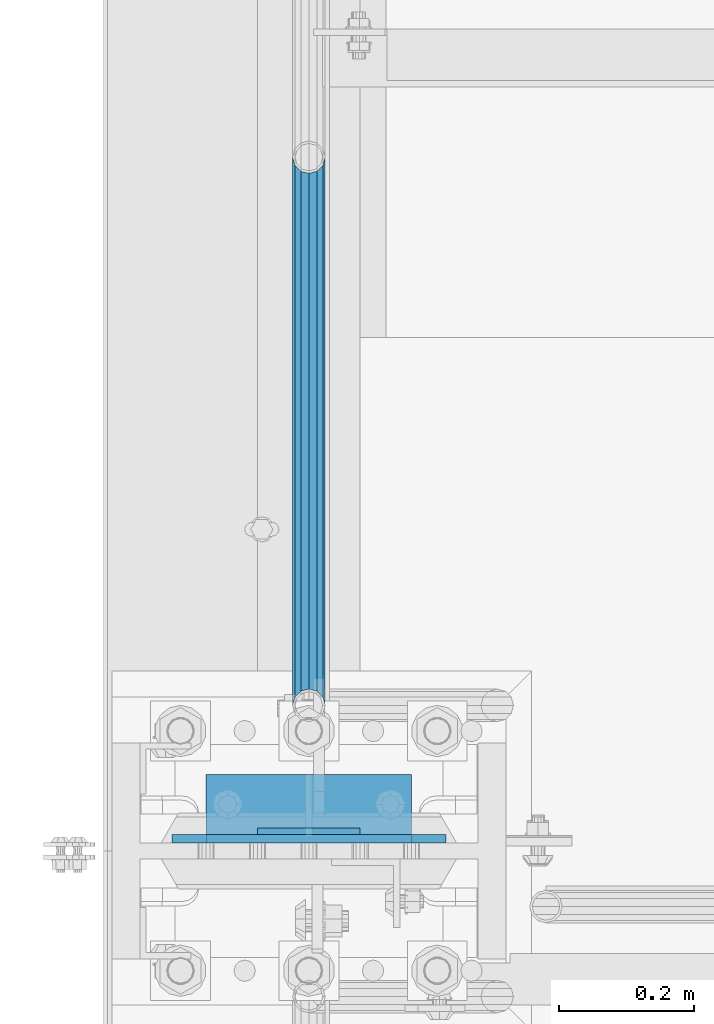
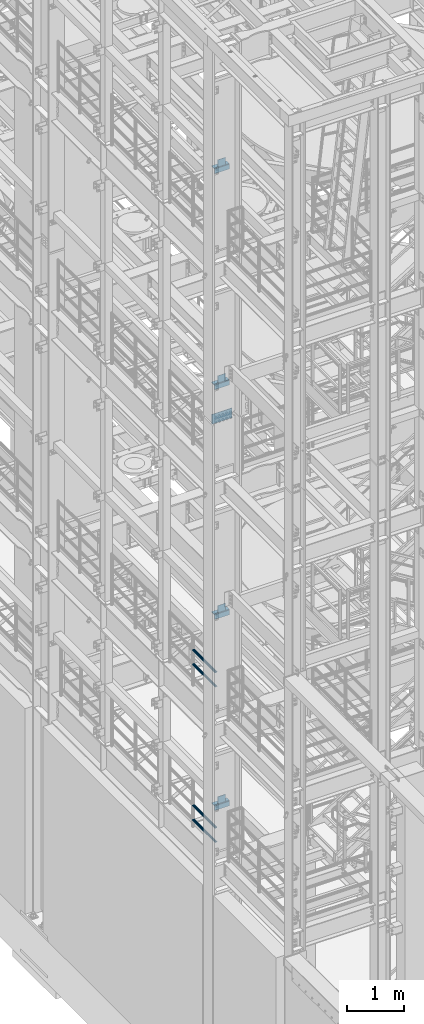
# One storey, part 1162 of 1876: 17 beams, 8 elements without a shape of their own.
"""IFC2X3 building model written with IfcOpenShell, lengths in millimetres."""

from ifc_helpers import new_model, si_unit, frame, origin_with_axes, place, context, subcontext, project, spatial, faceted_brep, material, type_object, element, aggregate, save


model = new_model("IFC2X3")

# Units and contexts
model_context = context("Model", 3, precision=1e-05, world=origin_with_axes())
body_context = subcontext(model_context, "Body", "Model", "MODEL_VIEW")
ifc_project = project(units=[si_unit("LENGTHUNIT", "METRE", prefix="MILLI"), si_unit("AREAUNIT", "SQUARE_METRE"), si_unit("VOLUMEUNIT", "CUBIC_METRE"), si_unit("MASSUNIT", "GRAM", prefix="KILO"), si_unit("TIMEUNIT", "SECOND"), si_unit("PLANEANGLEUNIT", "RADIAN"), si_unit("SOLIDANGLEUNIT", "STERADIAN"), si_unit("THERMODYNAMICTEMPERATUREUNIT", "DEGREE_CELSIUS"), si_unit("LUMINOUSINTENSITYUNIT", "LUMEN")], contexts=[model_context])

# Site, building, storey
site_placement = place(None, origin_with_axes())
site = spatial("IfcSite", under=ifc_project, at=site_placement, CompositionType="ELEMENT")
building_placement = place(site_placement, origin_with_axes())
building = spatial("IfcBuilding", under=site, at=building_placement, Name="Undefined", CompositionType="ELEMENT")
storey_placement = place(building_placement, origin_with_axes())
storey = spatial("IfcBuildingStorey", under=building, at=storey_placement, Name="Undefined", CompositionType="ELEMENT", Elevation=0.0)

# Assembly, beam
assembly_1_placement = place(storey_placement, origin_with_axes())
assembly_1 = element("IfcElementAssembly", 1, at=assembly_1_placement, inside=storey, Name="BEAM", AssemblyPlace="NOTDEFINED", PredefinedType="RIGID_FRAME")
ifc_material_1 = material(Name="STEEL/A36")
beam_type_1 = type_object("IfcBeamType", PredefinedType="NOTDEFINED")
beam_1_placement = place(assembly_1_placement, frame((76.1999999999998, -4542.63125, 19958.05), z_axis=(0.0, 0.0, 1.0), x_axis=(-1.0, 0.0, 0.0)))
beam_1 = element("IfcBeam", 2, at=beam_1_placement, type_object=beam_type_1, material=ifc_material_1, Name="PLATE", context=body_context, shape_type="Brep", body=[
    faceted_brep([(0.0, 4.76249999999982, -76.1999999999998), (3.63797880709171e-12, 4.76249999999982, 76.1999969482422), (152.399993896484, 4.76250000000073, 76.1999969482422), (152.4, 4.76249999999982, -76.1999999999998), (3.63797880709171e-12, -4.76249999999982, 76.1999969482422), (152.399993896484, -4.76250000000073, 76.1999969482422), (0.0, -4.76249999999982, -76.1999999999998), (152.4, -4.76249999999982, -76.1999999999998)], [[[0, 1, 2, 3]], [[4, 5, 2, 1]], [[4, 6, 7, 5]], [[6, 0, 3, 7]], [[5, 7, 3, 2]], [[6, 4, 1, 0]]]),
])

assembly_2_placement = place(storey_placement, origin_with_axes())
assembly_2 = element("IfcElementAssembly", 3, at=assembly_2_placement, inside=storey, Name="BEAM", AssemblyPlace="NOTDEFINED", PredefinedType="RIGID_FRAME")
beam_2_placement = place(assembly_2_placement, frame((76.1999999999998, -4542.63125, 15335.25), z_axis=(0.0, 0.0, 1.0), x_axis=(-1.0, 0.0, 0.0)))
beam_2 = element("IfcBeam", 4, at=beam_2_placement, type_object=beam_type_1, material=ifc_material_1, Name="PLATE", context=body_context, shape_type="Brep", body=[
    faceted_brep([(0.0, 4.76249999999982, -76.1999999999998), (3.63797880709171e-12, 4.76249999999982, 76.1999969482422), (152.399993896484, 4.76250000000073, 76.1999969482422), (152.4, 4.76249999999982, -76.1999999999998), (3.63797880709171e-12, -4.76249999999982, 76.1999969482422), (152.399993896484, -4.76250000000073, 76.1999969482422), (0.0, -4.76249999999982, -76.1999999999998), (152.4, -4.76249999999982, -76.1999999999998)], [[[0, 1, 2, 3]], [[4, 5, 2, 1]], [[4, 6, 7, 5]], [[6, 0, 3, 7]], [[5, 7, 3, 2]], [[6, 4, 1, 0]]]),
])

assembly_3_placement = place(storey_placement, origin_with_axes())
assembly_3 = element("IfcElementAssembly", 5, at=assembly_3_placement, inside=storey, Name="BEAM", AssemblyPlace="NOTDEFINED", PredefinedType="RIGID_FRAME")
beam_3_placement = place(assembly_3_placement, frame((76.1999999999998, -4542.63125, 10420.35), z_axis=(0.0, 0.0, 1.0), x_axis=(-1.0, 0.0, 0.0)))
beam_3 = element("IfcBeam", 6, at=beam_3_placement, type_object=beam_type_1, material=ifc_material_1, Name="PLATE", context=body_context, shape_type="Brep", body=[
    faceted_brep([(0.0, 4.76249999999982, -76.1999999999998), (3.63797880709171e-12, 4.76249999999982, 76.1999969482422), (152.399993896484, 4.76250000000073, 76.1999969482422), (152.4, 4.76249999999982, -76.1999999999998), (3.63797880709171e-12, -4.76249999999982, 76.1999969482422), (152.399993896484, -4.76250000000073, 76.1999969482422), (0.0, -4.76249999999982, -76.1999999999998), (152.4, -4.76249999999982, -76.1999999999998)], [[[0, 1, 2, 3]], [[4, 5, 2, 1]], [[4, 6, 7, 5]], [[6, 0, 3, 7]], [[5, 7, 3, 2]], [[6, 4, 1, 0]]]),
])

assembly_4_placement = place(storey_placement, origin_with_axes())
assembly_4 = element("IfcElementAssembly", 7, at=assembly_4_placement, inside=storey, Name="BEAM", AssemblyPlace="NOTDEFINED", PredefinedType="RIGID_FRAME")
beam_4_placement = place(assembly_4_placement, frame((76.1999999999998, -4542.63125, 6330.95), z_axis=(0.0, 0.0, 1.0), x_axis=(-1.0, 0.0, 0.0)))
beam_4 = element("IfcBeam", 8, at=beam_4_placement, type_object=beam_type_1, material=ifc_material_1, Name="PLATE", context=body_context, shape_type="Brep", body=[
    faceted_brep([(0.0, 4.76249999999982, -76.1999999999998), (3.63797880709171e-12, 4.76249999999982, 76.1999969482422), (152.399993896484, 4.76250000000073, 76.1999969482422), (152.4, 4.76249999999982, -76.1999999999998), (3.63797880709171e-12, -4.76249999999982, 76.1999969482422), (152.399993896484, -4.76250000000073, 76.1999969482422), (0.0, -4.76249999999982, -76.1999999999998), (152.4, -4.76249999999982, -76.1999999999998)], [[[0, 1, 2, 3]], [[4, 5, 2, 1]], [[4, 6, 7, 5]], [[6, 0, 3, 7]], [[5, 7, 3, 2]], [[6, 4, 1, 0]]]),
])

# Assembly, beams
assembly_5_placement = place(storey_placement, origin_with_axes())
assembly_5 = element("IfcElementAssembly", 9, at=assembly_5_placement, inside=storey, Name="RAIL", AssemblyPlace="NOTDEFINED", PredefinedType="RIGID_FRAME")
ifc_material_2 = material()
beam_type_2 = type_object("IfcBeamType", Name="PIPE1-1/2SCH40", PredefinedType="NOTDEFINED")
beam_5_placement = place(assembly_5_placement, frame((-1.00044417195022e-11, -4356.1, 8620.125000036), z_axis=(0.0, 0.0, -1.0), x_axis=(0.0, 1.0, 0.0)))
beam_5 = element("IfcBeam", 10, at=beam_5_placement, type_object=beam_type_2, material=ifc_material_2, Name="RAIL", ObjectType="PIPE1-1/2SCH40", context=body_context, shape_type="Brep", body=[
    faceted_brep([(0.0, 24.1299999999992, 0.0), (12.0650000000064, 20.8971929933177, -12.0649999999987), (12.0650000000064, 20.8971929933177, 12.0649999999987), (12.0650000000064, -20.8971929933177, 12.0649999999987), (12.0650000000064, -20.8971929933177, -12.0649999999987), (0.0, -24.1299999999992, 0.0), (20.8971929933249, -12.0650000000005, 20.8971929933177), (20.8971929933249, -12.0650000000005, 15.8661214311796), (15.2545715621445, -17.7076214311801, 10.2235000000001), (12.5151929933249, -20.4470000000001, 0.0), (15.2545715621445, -17.7076214311801, -10.2235000000001), (20.8971929933249, -12.0650000000005, -15.8661214311796), (20.8971929933249, -12.0650000000005, -20.8971929933177), (24.1300000000063, 0.0, -20.4470000000001), (24.1300000000063, 0.0, -24.130000000001), (21.3906214311868, -10.2235000000001, -17.7076214311819), (21.3906214311868, 10.2235000000001, -17.7076214311819), (20.8971929933249, 12.0650000000005, -15.8661214311796), (20.8971929933249, 12.0650000000005, -20.8971929933177), (15.2545715621445, 17.7076214311801, -10.2235000000001), (12.5151929933249, 20.4470000000001, 0.0), (15.2545715621445, 17.7076214311801, 10.2235000000001), (20.8971929933249, 12.0650000000005, 15.8661214311796), (20.8971929933249, 12.0650000000005, 20.8971929933177), (21.3906214311868, 10.2235000000001, 17.7076214311819), (24.1300000000064, 0.0, 20.4470000000001), (24.1300000000064, 0.0, 24.130000000001), (21.3906214311868, -10.2235000000001, 17.7076214311819), (813.396900000002, 24.1300000000001, 0.0), (801.331900000001, 20.8971929933186, -12.0649999999987), (792.499707006684, 12.0649999999996, -20.8971929933177), (813.396900000002, -24.1300000000319, 0.0), (801.331900000001, -20.8971929933186, -12.0649999999987), (801.331900000001, -20.8971929933186, 12.0649999999987), (792.499707006684, -12.0649999999996, 20.8971929933177), (792.499707006684, -12.0649999999996, -20.8971929933177), (789.266900000001, 0.0, -24.130000000001), (792.00627856883, 10.2235000000001, -17.7076214311819), (789.266900000001, 0.0, -20.4470000000001), (792.499707006684, 12.0649999999678, -15.8661214312124), (792.499707006684, -12.0650000000314, -15.8661214311469), (792.006278568813, -10.2235000000001, -17.7076214311819), (798.142328437831, -17.7076214311801, -10.2235000000001), (800.881707006651, -20.4470000000001, 0.0), (798.142328437831, -17.7076214311801, 10.2235000000001), (792.499707006684, -12.0650000000314, 15.8661214311469), (792.006278568813, -10.2235000000001, 17.7076214311819), (789.266900000001, -9.09494701772928e-13, 20.4470000000001), (789.266900000001, -9.09494701772928e-13, 24.130000000001), (792.499707006684, 12.0649999999996, 20.8971929933177), (801.331900000001, 20.8971929933186, 12.0649999999987), (792.499707006684, 12.0649999999678, 15.8661214312124), (798.142328437896, 17.7076214311801, 10.2235000000001), (800.881707006714, 20.4470000000001, 0.0), (798.142328437896, 17.7076214311801, -10.2235000000001), (792.00627856883, 10.2235000000001, 17.7076214311819)], [[[0, 1, 2]], [[3, 4, 5]], [[6, 7, 8, 9, 10, 11, 12, 4, 3]], [[13, 14, 12, 11, 15]], [[16, 17, 18, 14, 13]], [[2, 1, 18, 17, 19, 20, 21, 22, 23]], [[23, 22, 24, 25, 26]], [[26, 25, 27, 7, 6]], [[1, 0, 28, 29]], [[18, 1, 29, 30]], [[31, 32, 33]], [[6, 3, 33, 34]], [[3, 5, 31, 33]], [[5, 4, 32, 31]], [[4, 12, 35, 32]], [[12, 14, 36, 35]], [[14, 18, 30, 36]], [[37, 38, 36, 30, 39]], [[40, 35, 36, 38, 41]], [[33, 32, 35, 40, 42, 43, 44, 45, 34]], [[34, 45, 46, 47, 48]], [[26, 6, 34, 48]], [[2, 23, 49, 50]], [[23, 26, 48, 49]], [[0, 2, 50, 28]], [[28, 50, 29]], [[49, 51, 52, 53, 54, 39, 30, 29, 50]], [[48, 47, 55, 51, 49]], [[25, 24, 55, 47]], [[55, 24, 22, 21, 52, 51]], [[21, 20, 53, 52]], [[20, 19, 54, 53]], [[19, 17, 16, 37, 39, 54]], [[16, 13, 38, 37]], [[13, 15, 41, 38]], [[41, 15, 11, 10, 42, 40]], [[10, 9, 43, 42]], [[9, 8, 44, 43]], [[8, 7, 27, 46, 45, 44]], [[27, 25, 47, 46]]]),
])
beam_6_placement = place(assembly_5_placement, frame((-1.00044417195022e-11, -4356.1, 8924.92500003594), z_axis=(0.0, 0.0, -1.0), x_axis=(0.0, 1.0, 0.0)))
beam_6 = element("IfcBeam", 11, at=beam_6_placement, type_object=beam_type_2, material=ifc_material_2, Name="RAIL", ObjectType="PIPE1-1/2SCH40", context=body_context, shape_type="Brep", body=[
    faceted_brep([(0.0, 24.1299999999992, 0.0), (12.0650000000064, 20.8971929933177, -12.0649999999987), (12.0650000000064, 20.8971929933177, 12.0649999999987), (12.0650000000064, -20.8971929933177, 12.0649999999987), (12.0650000000064, -20.8971929933177, -12.0649999999987), (0.0, -24.1299999999992, 0.0), (20.8971929933249, -12.0650000000005, 20.8971929933177), (20.8971929933249, -12.0650000000005, 15.8661214311796), (15.2545715621445, -17.7076214311801, 10.2235000000001), (12.5151929933249, -20.4470000000001, 0.0), (15.2545715621445, -17.7076214311801, -10.2235000000001), (20.8971929933249, -12.0650000000005, -15.8661214311796), (20.8971929933249, -12.0650000000005, -20.8971929933177), (24.1300000000063, 0.0, -20.4470000000001), (24.1300000000063, 0.0, -24.130000000001), (21.3906214311868, -10.2235000000001, -17.7076214311819), (21.3906214311868, 10.2235000000001, -17.7076214311819), (20.8971929933249, 12.0650000000005, -15.8661214311796), (20.8971929933249, 12.0650000000005, -20.8971929933177), (15.2545715621445, 17.7076214311801, -10.2235000000001), (12.5151929933249, 20.4470000000001, 0.0), (15.2545715621445, 17.7076214311801, 10.2235000000001), (20.8971929933249, 12.0650000000005, 15.8661214311796), (20.8971929933249, 12.0650000000005, 20.8971929933177), (21.3906214311868, 10.2235000000001, 17.7076214311819), (24.1300000000064, 0.0, 20.4470000000001), (24.1300000000064, 0.0, 24.130000000001), (21.3906214311868, -10.2235000000001, 17.7076214311819), (813.396900000002, 24.1300000000001, 0.0), (801.331900000001, 20.8971929933186, -12.0649999999987), (792.499707006684, 12.0649999999996, -20.8971929933177), (813.396900000002, -24.1300000000319, 0.0), (801.331900000001, -20.8971929933186, -12.0649999999987), (801.331900000001, -20.8971929933186, 12.0649999999987), (792.499707006684, -12.0649999999996, 20.8971929933177), (792.499707006684, -12.0649999999996, -20.8971929933177), (789.266900000001, 0.0, -24.130000000001), (792.00627856883, 10.2235000000001, -17.7076214311819), (789.266900000001, 0.0, -20.4470000000001), (792.499707006684, 12.0649999999678, -15.8661214312124), (792.499707006684, -12.0650000000314, -15.8661214311469), (792.006278568813, -10.2235000000001, -17.7076214311819), (798.142328437831, -17.7076214311801, -10.2235000000001), (800.881707006651, -20.4470000000001, 0.0), (798.142328437831, -17.7076214311801, 10.2235000000001), (792.499707006684, -12.0650000000314, 15.8661214311469), (792.006278568813, -10.2235000000001, 17.7076214311819), (789.266900000001, -9.09494701772928e-13, 20.4470000000001), (789.266900000001, -9.09494701772928e-13, 24.130000000001), (792.499707006684, 12.0649999999996, 20.8971929933177), (801.331900000001, 20.8971929933186, 12.0649999999987), (792.499707006684, 12.0649999999678, 15.8661214312124), (798.142328437896, 17.7076214311801, 10.2235000000001), (800.881707006714, 20.4470000000001, 0.0), (798.142328437896, 17.7076214311801, -10.2235000000001), (792.00627856883, 10.2235000000001, 17.7076214311819)], [[[0, 1, 2]], [[3, 4, 5]], [[6, 7, 8, 9, 10, 11, 12, 4, 3]], [[13, 14, 12, 11, 15]], [[16, 17, 18, 14, 13]], [[2, 1, 18, 17, 19, 20, 21, 22, 23]], [[23, 22, 24, 25, 26]], [[26, 25, 27, 7, 6]], [[1, 0, 28, 29]], [[18, 1, 29, 30]], [[31, 32, 33]], [[6, 3, 33, 34]], [[3, 5, 31, 33]], [[5, 4, 32, 31]], [[4, 12, 35, 32]], [[12, 14, 36, 35]], [[14, 18, 30, 36]], [[37, 38, 36, 30, 39]], [[40, 35, 36, 38, 41]], [[33, 32, 35, 40, 42, 43, 44, 45, 34]], [[34, 45, 46, 47, 48]], [[26, 6, 34, 48]], [[2, 23, 49, 50]], [[23, 26, 48, 49]], [[0, 2, 50, 28]], [[28, 50, 29]], [[49, 51, 52, 53, 54, 39, 30, 29, 50]], [[48, 47, 55, 51, 49]], [[25, 24, 55, 47]], [[55, 24, 22, 21, 52, 51]], [[21, 20, 53, 52]], [[20, 19, 54, 53]], [[19, 17, 16, 37, 39, 54]], [[16, 13, 38, 37]], [[13, 15, 41, 38]], [[41, 15, 11, 10, 42, 40]], [[10, 9, 43, 42]], [[9, 8, 44, 43]], [[8, 7, 27, 46, 45, 44]], [[27, 25, 47, 46]]]),
])
aggregate(assembly_5, [beam_5, beam_6])

assembly_6_placement = place(storey_placement, origin_with_axes())
assembly_6 = element("IfcElementAssembly", 12, at=assembly_6_placement, inside=storey, Name="RAIL", AssemblyPlace="NOTDEFINED", PredefinedType="RIGID_FRAME")
beam_7_placement = place(assembly_6_placement, frame((6.13908923696727e-12, -3542.7031, 5292.725), z_axis=(0.0, 0.0, 1.0), x_axis=(0.0, -1.0, 0.0)))
beam_7 = element("IfcBeam", 13, at=beam_7_placement, type_object=beam_type_2, material=ifc_material_2, Name="RAIL", ObjectType="PIPE1-1/2SCH40", context=body_context, shape_type="Brep", body=[
    faceted_brep([(792.499707006684, -12.0649999999996, 20.8971929933177), (792.499707006684, -12.0650000000314, 15.8661214311469), (792.006278568813, -10.2235000000001, 17.7076214311819), (789.266900000001, -9.09494701772928e-13, 20.4470000000001), (789.266900000001, -9.09494701772928e-13, 24.130000000001), (792.00627856883, 10.2235000000001, 17.7076214311819), (792.499707006684, 12.0649999999678, 15.8661214312124), (792.499707006684, 12.0649999999996, 20.8971929933177), (813.396900000002, 24.1300000000001, 0.0), (801.331900000001, 20.8971929933186, 12.0649999999987), (801.331900000001, 20.8971929933186, -12.0649999999987), (798.142328437896, 17.7076214311801, 10.2235000000001), (800.881707006714, 20.4470000000001, 0.0), (798.142328437896, 17.7076214311801, -10.2235000000001), (792.499707006684, 12.0649999999678, -15.8661214312124), (792.499707006684, 12.0649999999996, -20.8971929933177), (792.00627856883, 10.2235000000001, -17.7076214311819), (789.266900000001, 0.0, -20.4470000000001), (789.266900000001, 0.0, -24.130000000001), (792.499707006684, -12.0650000000314, -15.8661214311469), (792.499707006684, -12.0649999999996, -20.8971929933177), (792.006278568813, -10.2235000000001, -17.7076214311819), (813.396900000002, -24.1300000000319, 0.0), (801.331900000001, -20.8971929933186, -12.0649999999987), (801.331900000001, -20.8971929933186, 12.0649999999987), (798.142328437831, -17.7076214311801, -10.2235000000001), (800.881707006651, -20.4470000000001, 0.0), (798.142328437831, -17.7076214311801, 10.2235000000001), (12.0650000000064, -20.8971929933177, -12.0649999999987), (20.8971929933249, -12.0650000000005, -20.8971929933177), (0.0, 24.1299999999992, 0.0), (12.0650000000064, 20.8971929933177, -12.0649999999987), (12.0650000000064, 20.8971929933177, 12.0649999999987), (20.8971929933249, 12.0650000000005, 20.8971929933177), (24.1300000000064, 0.0, 24.130000000001), (20.8971929933249, 12.0650000000005, -20.8971929933177), (24.1300000000063, 0.0, -24.130000000001), (24.1300000000063, 0.0, -20.4470000000001), (20.8971929933249, -12.0650000000005, -15.8661214311796), (21.3906214311868, -10.2235000000001, -17.7076214311819), (21.3906214311868, 10.2235000000001, -17.7076214311819), (20.8971929933249, 12.0650000000005, -15.8661214311796), (15.2545715621445, 17.7076214311801, -10.2235000000001), (12.5151929933249, 20.4470000000001, 0.0), (15.2545715621445, 17.7076214311801, 10.2235000000001), (20.8971929933249, 12.0650000000005, 15.8661214311796), (21.3906214311868, 10.2235000000001, 17.7076214311819), (24.1300000000064, 0.0, 20.4470000000001), (21.3906214311868, -10.2235000000001, 17.7076214311819), (20.8971929933249, -12.0650000000005, 15.8661214311796), (20.8971929933249, -12.0650000000005, 20.8971929933177), (12.0650000000064, -20.8971929933177, 12.0649999999987), (0.0, -24.1299999999992, 0.0), (15.2545715621445, -17.7076214311801, 10.2235000000001), (12.5151929933249, -20.4470000000001, 0.0), (15.2545715621445, -17.7076214311801, -10.2235000000001)], [[[0, 1, 2, 3, 4]], [[4, 3, 5, 6, 7]], [[8, 9, 10]], [[7, 6, 11, 12, 13, 14, 15, 10, 9]], [[16, 17, 18, 15, 14]], [[19, 20, 18, 17, 21]], [[22, 23, 24]], [[24, 23, 20, 19, 25, 26, 27, 1, 0]], [[28, 29, 20, 23]], [[30, 31, 32]], [[33, 34, 4, 7]], [[32, 33, 7, 9]], [[30, 32, 9, 8]], [[31, 30, 8, 10]], [[35, 31, 10, 15]], [[36, 35, 15, 18]], [[29, 36, 18, 20]], [[37, 36, 29, 38, 39]], [[40, 41, 35, 36, 37]], [[32, 31, 35, 41, 42, 43, 44, 45, 33]], [[33, 45, 46, 47, 34]], [[34, 47, 48, 49, 50]], [[34, 50, 0, 4]], [[50, 51, 24, 0]], [[51, 52, 22, 24]], [[52, 28, 23, 22]], [[51, 28, 52]], [[50, 49, 53, 54, 55, 38, 29, 28, 51]], [[55, 54, 26, 25]], [[21, 39, 38, 55, 25, 19]], [[37, 39, 21, 17]], [[40, 37, 17, 16]], [[42, 41, 40, 16, 14, 13]], [[43, 42, 13, 12]], [[44, 43, 12, 11]], [[5, 46, 45, 44, 11, 6]], [[47, 46, 5, 3]], [[48, 47, 3, 2]], [[53, 49, 48, 2, 1, 27]], [[54, 53, 27, 26]]]),
])
beam_8_placement = place(assembly_6_placement, frame((-1.00044417195022e-11, -4356.1, 5597.525000036), z_axis=(0.0, 0.0, -1.0), x_axis=(0.0, 1.0, 0.0)))
beam_8 = element("IfcBeam", 14, at=beam_8_placement, type_object=beam_type_2, material=ifc_material_2, Name="RAIL", ObjectType="PIPE1-1/2SCH40", context=body_context, shape_type="Brep", body=[
    faceted_brep([(0.0, 24.1299999999992, 0.0), (12.0650000000064, 20.8971929933177, -12.0649999999987), (12.0650000000064, 20.8971929933177, 12.0649999999987), (12.0650000000064, -20.8971929933177, 12.0649999999987), (12.0650000000064, -20.8971929933177, -12.0649999999987), (0.0, -24.1299999999992, 0.0), (20.8971929933249, -12.0650000000005, 20.8971929933177), (20.8971929933249, -12.0650000000005, 15.8661214311796), (15.2545715621445, -17.7076214311801, 10.2235000000001), (12.5151929933249, -20.4470000000001, 0.0), (15.2545715621445, -17.7076214311801, -10.2235000000001), (20.8971929933249, -12.0650000000005, -15.8661214311796), (20.8971929933249, -12.0650000000005, -20.8971929933177), (24.1300000000063, 0.0, -20.4470000000001), (24.1300000000063, 0.0, -24.130000000001), (21.3906214311868, -10.2235000000001, -17.7076214311819), (21.3906214311868, 10.2235000000001, -17.7076214311819), (20.8971929933249, 12.0650000000005, -15.8661214311796), (20.8971929933249, 12.0650000000005, -20.8971929933177), (15.2545715621445, 17.7076214311801, -10.2235000000001), (12.5151929933249, 20.4470000000001, 0.0), (15.2545715621445, 17.7076214311801, 10.2235000000001), (20.8971929933249, 12.0650000000005, 15.8661214311796), (20.8971929933249, 12.0650000000005, 20.8971929933177), (21.3906214311868, 10.2235000000001, 17.7076214311819), (24.1300000000064, 0.0, 20.4470000000001), (24.1300000000064, 0.0, 24.130000000001), (21.3906214311868, -10.2235000000001, 17.7076214311819), (813.396900000002, 24.1300000000001, 0.0), (801.331900000001, 20.8971929933186, -12.0649999999987), (792.499707006684, 12.0649999999996, -20.8971929933177), (813.396900000002, -24.1300000000319, 0.0), (801.331900000001, -20.8971929933186, -12.0649999999987), (801.331900000001, -20.8971929933186, 12.0649999999987), (792.499707006684, -12.0649999999996, 20.8971929933177), (792.499707006684, -12.0649999999996, -20.8971929933177), (789.266900000001, 0.0, -24.130000000001), (792.00627856883, 10.2235000000001, -17.7076214311819), (789.266900000001, 0.0, -20.4470000000001), (792.499707006684, 12.0649999999678, -15.8661214312124), (792.499707006684, -12.0650000000314, -15.8661214311469), (792.006278568813, -10.2235000000001, -17.7076214311819), (798.142328437831, -17.7076214311801, -10.2235000000001), (800.881707006651, -20.4470000000001, 0.0), (798.142328437831, -17.7076214311801, 10.2235000000001), (792.499707006684, -12.0650000000314, 15.8661214311469), (792.006278568813, -10.2235000000001, 17.7076214311819), (789.266900000001, -9.09494701772928e-13, 20.4470000000001), (789.266900000001, -9.09494701772928e-13, 24.130000000001), (792.499707006684, 12.0649999999996, 20.8971929933177), (801.331900000001, 20.8971929933186, 12.0649999999987), (792.499707006684, 12.0649999999678, 15.8661214312124), (798.142328437896, 17.7076214311801, 10.2235000000001), (800.881707006714, 20.4470000000001, 0.0), (798.142328437896, 17.7076214311801, -10.2235000000001), (792.00627856883, 10.2235000000001, 17.7076214311819)], [[[0, 1, 2]], [[3, 4, 5]], [[6, 7, 8, 9, 10, 11, 12, 4, 3]], [[13, 14, 12, 11, 15]], [[16, 17, 18, 14, 13]], [[2, 1, 18, 17, 19, 20, 21, 22, 23]], [[23, 22, 24, 25, 26]], [[26, 25, 27, 7, 6]], [[1, 0, 28, 29]], [[18, 1, 29, 30]], [[31, 32, 33]], [[6, 3, 33, 34]], [[3, 5, 31, 33]], [[5, 4, 32, 31]], [[4, 12, 35, 32]], [[12, 14, 36, 35]], [[14, 18, 30, 36]], [[37, 38, 36, 30, 39]], [[40, 35, 36, 38, 41]], [[33, 32, 35, 40, 42, 43, 44, 45, 34]], [[34, 45, 46, 47, 48]], [[26, 6, 34, 48]], [[2, 23, 49, 50]], [[23, 26, 48, 49]], [[0, 2, 50, 28]], [[28, 50, 29]], [[49, 51, 52, 53, 54, 39, 30, 29, 50]], [[48, 47, 55, 51, 49]], [[25, 24, 55, 47]], [[55, 24, 22, 21, 52, 51]], [[21, 20, 53, 52]], [[20, 19, 54, 53]], [[19, 17, 16, 37, 39, 54]], [[16, 13, 38, 37]], [[13, 15, 41, 38]], [[41, 15, 11, 10, 42, 40]], [[10, 9, 43, 42]], [[9, 8, 44, 43]], [[8, 7, 27, 46, 45, 44]], [[27, 25, 47, 46]]]),
])
aggregate(assembly_6, [beam_7, beam_8])

# Beam
beam_type_3 = type_object("IfcBeamType", PredefinedType="NOTDEFINED")
beam_9_placement = place(assembly_1_placement, frame((-152.400000000001, -4502.94375, 19877.0875), z_axis=(0.0, 1.0, 0.0), x_axis=(1.0, 0.0, 0.0)))
beam_9 = element("IfcBeam", 15, at=beam_9_placement, type_object=beam_type_3, material=ifc_material_1, Name="PLATE", context=body_context, shape_type="Brep", body=[
    faceted_brep([(0.0, 4.76250000000073, -44.4499999999998), (0.0, 4.76250000000073, 44.4499999999998), (304.799999999999, 4.76250000000073, 44.4499999999998), (304.799999999999, 4.76250000000073, -44.4499999999998), (0.0, -4.76250000000073, 44.4499999999998), (304.799999999999, -4.76250000000073, 44.4499999999998), (0.0, -4.76250000000073, -44.4499999999998), (304.799999999999, -4.76250000000073, -44.4499999999998)], [[[0, 1, 2, 3]], [[1, 4, 5, 2]], [[4, 6, 7, 5]], [[6, 0, 3, 7]], [[5, 7, 3, 2]], [[6, 4, 1, 0]]]),
])

aggregate(assembly_1, [beam_1, beam_9])

beam_10_placement = place(assembly_2_placement, frame((-152.400000000001, -4502.94375, 15254.2875), z_axis=(0.0, 1.0, 0.0), x_axis=(1.0, 0.0, 0.0)))
beam_10 = element("IfcBeam", 16, at=beam_10_placement, type_object=beam_type_3, material=ifc_material_1, Name="PLATE", context=body_context, shape_type="Brep", body=[
    faceted_brep([(0.0, 4.76250000000073, -44.4499999999998), (0.0, 4.76250000000073, 44.4499999999998), (304.799999999999, 4.76250000000073, 44.4499999999998), (304.799999999999, 4.76250000000073, -44.4499999999998), (0.0, -4.76250000000073, 44.4499999999998), (304.799999999999, -4.76250000000073, 44.4499999999998), (0.0, -4.76250000000073, -44.4499999999998), (304.799999999999, -4.76250000000073, -44.4499999999998)], [[[0, 1, 2, 3]], [[1, 4, 5, 2]], [[4, 6, 7, 5]], [[6, 0, 3, 7]], [[5, 7, 3, 2]], [[6, 4, 1, 0]]]),
])

aggregate(assembly_2, [beam_2, beam_10])

beam_11_placement = place(assembly_3_placement, frame((-152.400000000001, -4502.94375, 10339.3875), z_axis=(0.0, 1.0, 0.0), x_axis=(1.0, 0.0, 0.0)))
beam_11 = element("IfcBeam", 17, at=beam_11_placement, type_object=beam_type_3, material=ifc_material_1, Name="PLATE", context=body_context, shape_type="Brep", body=[
    faceted_brep([(0.0, 4.76250000000073, -44.4499999999998), (0.0, 4.76250000000073, 44.4499999999998), (304.799999999999, 4.76250000000073, 44.4499999999998), (304.799999999999, 4.76250000000073, -44.4499999999998), (0.0, -4.76250000000073, 44.4499999999998), (304.799999999999, -4.76250000000073, 44.4499999999998), (0.0, -4.76250000000073, -44.4499999999998), (304.799999999999, -4.76250000000073, -44.4499999999998)], [[[0, 1, 2, 3]], [[1, 4, 5, 2]], [[4, 6, 7, 5]], [[6, 0, 3, 7]], [[5, 7, 3, 2]], [[6, 4, 1, 0]]]),
])

aggregate(assembly_3, [beam_3, beam_11])

beam_12_placement = place(assembly_4_placement, frame((-152.400000000001, -4502.94375, 6249.9875), z_axis=(0.0, 1.0, 0.0), x_axis=(1.0, 0.0, 0.0)))
beam_12 = element("IfcBeam", 18, at=beam_12_placement, type_object=beam_type_3, material=ifc_material_1, Name="PLATE", context=body_context, shape_type="Brep", body=[
    faceted_brep([(0.0, 4.76250000000073, -44.4499999999998), (0.0, 4.76250000000073, 44.4499999999998), (304.799999999999, 4.76250000000073, 44.4499999999998), (304.799999999999, 4.76250000000073, -44.4499999999998), (0.0, -4.76250000000073, 44.4499999999998), (304.799999999999, -4.76250000000073, 44.4499999999998), (0.0, -4.76250000000073, -44.4499999999998), (304.799999999999, -4.76250000000073, -44.4499999999998)], [[[0, 1, 2, 3]], [[1, 4, 5, 2]], [[4, 6, 7, 5]], [[6, 0, 3, 7]], [[5, 7, 3, 2]], [[6, 4, 1, 0]]]),
])

aggregate(assembly_4, [beam_4, beam_12])

# Assembly, beams
assembly_7_placement = place(storey_placement, origin_with_axes())
assembly_7 = element("IfcElementAssembly", 19, at=assembly_7_placement, inside=storey, Name="COLUMN", AssemblyPlace="NOTDEFINED", PredefinedType="RIGID_FRAME")
beam_type_4 = type_object("IfcBeamType", Name="L4X4X3/8", PredefinedType="NOTDEFINED")
beam_13_placement = place(assembly_7_placement, frame((152.4, -4509.29375, 19821.525), z_axis=(0.0, 1.0, 0.0), x_axis=(-1.0, 0.0, 0.0)))
beam_13 = element("IfcBeam", 20, at=beam_13_placement, type_object=beam_type_4, material=ifc_material_1, Name="ANGLE", ObjectType="L4X4X3/8", context=body_context, shape_type="Brep", body=[
    faceted_brep([(0.0, 50.7999999999993, -50.8000000000002), (0.0, 50.7999999999993, 50.8000000000002), (304.799999999999, 50.7999999999993, 50.8000000000002), (304.799999999999, 50.7999999999993, -50.8000000000002), (0.0, 41.2750000000015, 50.8000000000002), (304.799999999999, 41.2750000000015, 50.8000000000002), (0.0, 41.2750000000015, -41.2749999999996), (304.799999999999, 41.2750000000015, -41.2749999999996), (0.0, -50.7999999999993, -41.2749999999996), (304.799999999999, -50.7999999999993, -41.2749999999996), (0.0, -50.7999999999993, -50.8000000000002), (304.799999999999, -50.7999999999993, -50.8000000000002)], [[[0, 1, 2, 3]], [[1, 4, 5, 2]], [[4, 6, 7, 5]], [[6, 8, 9, 7]], [[8, 10, 11, 9]], [[10, 0, 3, 11]], [[5, 7, 9, 11, 3, 2]], [[10, 8, 6, 4, 1, 0]]]),
])
beam_14_placement = place(assembly_7_placement, frame((152.4, -4509.29375, 15198.725), z_axis=(0.0, 1.0, 0.0), x_axis=(-1.0, 0.0, 0.0)))
beam_14 = element("IfcBeam", 21, at=beam_14_placement, type_object=beam_type_4, material=ifc_material_1, Name="ANGLE", ObjectType="L4X4X3/8", context=body_context, shape_type="Brep", body=[
    faceted_brep([(0.0, 50.7999999999993, -50.8000000000002), (0.0, 50.7999999999993, 50.8000000000002), (304.799999999999, 50.7999999999993, 50.8000000000002), (304.799999999999, 50.7999999999993, -50.8000000000002), (0.0, 41.2750000000015, 50.8000000000002), (304.799999999999, 41.2750000000015, 50.8000000000002), (0.0, 41.2750000000015, -41.2749999999996), (304.799999999999, 41.2750000000015, -41.2749999999996), (0.0, -50.7999999999993, -41.2749999999996), (304.799999999999, -50.7999999999993, -41.2749999999996), (0.0, -50.7999999999993, -50.8000000000002), (304.799999999999, -50.7999999999993, -50.8000000000002)], [[[0, 1, 2, 3]], [[1, 4, 5, 2]], [[4, 6, 7, 5]], [[6, 8, 9, 7]], [[8, 10, 11, 9]], [[10, 0, 3, 11]], [[5, 7, 9, 11, 3, 2]], [[10, 8, 6, 4, 1, 0]]]),
])
aggregate(assembly_7, [beam_13, beam_14])

assembly_8_placement = place(storey_placement, origin_with_axes())
assembly_8 = element("IfcElementAssembly", 22, at=assembly_8_placement, inside=storey, Name="COLUMN", AssemblyPlace="NOTDEFINED", PredefinedType="RIGID_FRAME")
beam_15_placement = place(assembly_8_placement, frame((152.4, -4509.29375, 10283.825), z_axis=(0.0, 1.0, 0.0), x_axis=(-1.0, 0.0, 0.0)))
beam_15 = element("IfcBeam", 23, at=beam_15_placement, type_object=beam_type_4, material=ifc_material_1, Name="ANGLE", ObjectType="L4X4X3/8", context=body_context, shape_type="Brep", body=[
    faceted_brep([(0.0, 50.7999999999993, -50.8000000000002), (0.0, 50.7999999999993, 50.8000000000002), (304.799999999999, 50.7999999999993, 50.8000000000002), (304.799999999999, 50.7999999999993, -50.8000000000002), (0.0, 41.2750000000015, 50.8000000000002), (304.799999999999, 41.2750000000015, 50.8000000000002), (0.0, 41.2750000000015, -41.2749999999996), (304.799999999999, 41.2750000000015, -41.2749999999996), (0.0, -50.7999999999993, -41.2749999999996), (304.799999999999, -50.7999999999993, -41.2749999999996), (0.0, -50.7999999999993, -50.8000000000002), (304.799999999999, -50.7999999999993, -50.8000000000002)], [[[0, 1, 2, 3]], [[1, 4, 5, 2]], [[4, 6, 7, 5]], [[6, 8, 9, 7]], [[8, 10, 11, 9]], [[10, 0, 3, 11]], [[5, 7, 9, 11, 3, 2]], [[10, 8, 6, 4, 1, 0]]]),
])
beam_16_placement = place(assembly_8_placement, frame((152.4, -4509.29375, 6194.425), z_axis=(0.0, 1.0, 0.0), x_axis=(-1.0, 0.0, 0.0)))
beam_16 = element("IfcBeam", 24, at=beam_16_placement, type_object=beam_type_4, material=ifc_material_1, Name="ANGLE", ObjectType="L4X4X3/8", context=body_context, shape_type="Brep", body=[
    faceted_brep([(0.0, 50.7999999999993, -50.8000000000002), (0.0, 50.7999999999993, 50.8000000000002), (304.799999999999, 50.7999999999993, 50.8000000000002), (304.799999999999, 50.7999999999993, -50.8000000000002), (0.0, 41.2750000000015, 50.8000000000002), (304.799999999999, 41.2750000000015, 50.8000000000002), (0.0, 41.2750000000015, -41.2749999999996), (304.799999999999, 41.2750000000015, -41.2749999999996), (0.0, -50.7999999999993, -41.2749999999996), (304.799999999999, -50.7999999999993, -41.2749999999996), (0.0, -50.7999999999993, -50.8000000000002), (304.799999999999, -50.7999999999993, -50.8000000000002)], [[[0, 1, 2, 3]], [[1, 4, 5, 2]], [[4, 6, 7, 5]], [[6, 8, 9, 7]], [[8, 10, 11, 9]], [[10, 0, 3, 11]], [[5, 7, 9, 11, 3, 2]], [[10, 8, 6, 4, 1, 0]]]),
])
ifc_material_3 = material(Name="STEEL/A572-50")
beam_type_5 = type_object("IfcBeamType", PredefinedType="NOTDEFINED")
beam_17_placement = place(assembly_8_placement, frame((0.0, -4553.74375, 14636.75), z_axis=(-1.0, 0.0, 0.0), x_axis=(0.0, 0.0, -1.0)))
beam_17 = element("IfcBeam", 25, at=beam_17_placement, type_object=beam_type_5, material=ifc_material_3, Name="PLATE", context=body_context, shape_type="Brep", body=[
    faceted_brep([(0.0, 6.35000000000036, -203.2), (0.0, 6.35000000000036, 203.2), (209.550000000001, 6.35000000000036, 203.2), (209.550000000001, 6.35000000000036, -203.2), (0.0, -6.35000000000036, 203.2), (209.550000000001, -6.35000000000036, 203.2), (0.0, -6.35000000000036, -203.2), (209.550000000001, -6.35000000000036, -203.2)], [[[0, 1, 2, 3]], [[1, 4, 5, 2]], [[4, 6, 7, 5]], [[6, 0, 3, 7]], [[5, 7, 3, 2]], [[6, 4, 1, 0]]]),
])
aggregate(assembly_8, [beam_15, beam_16, beam_17])

save(model, "model.ifc")
